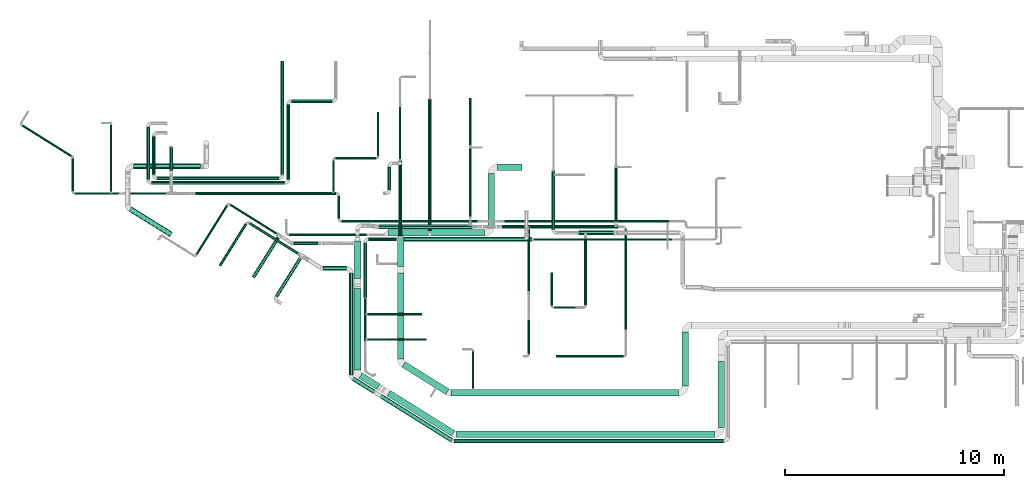
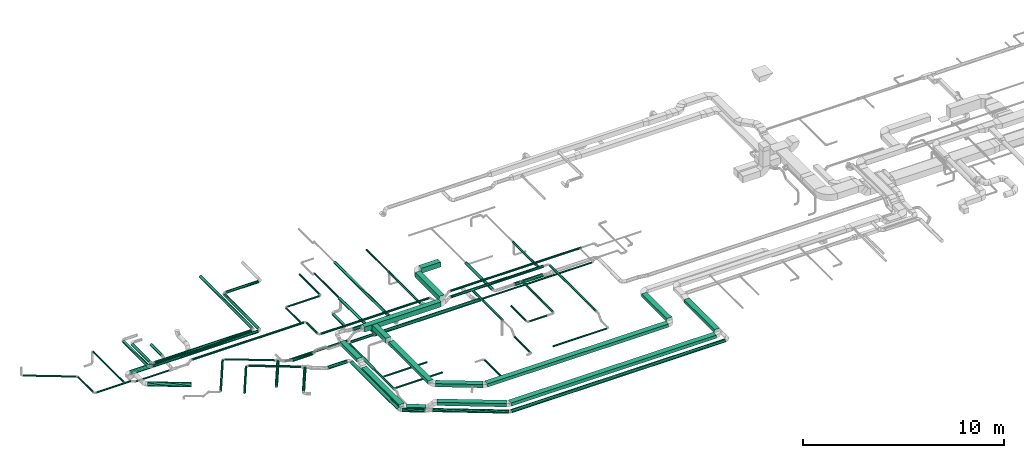
# One storey, part 1 of 60: 75 flow segments.
"""IFC2X3 building model written with IfcOpenShell, lengths in millimetres."""

from ifc_helpers import new_model, entity, si_unit, converted_unit, derived_unit, direction, frame, origin, origin_2d_with_axis, place, context, subcontext, project, spatial, rectangle, circle, extrude, type_object, element, save


model = new_model("IFC2X3")

# Units and contexts
model_context = context("Model", 3, precision=0.01, world=origin(), true_north=direction((6.12303176911189e-17, 1.0)))
body_context = subcontext(model_context, "Body", "Model", "MODEL_VIEW")
ifc_project = project(units=[si_unit("LENGTHUNIT", "METRE", prefix="MILLI"), si_unit("AREAUNIT", "SQUARE_METRE"), si_unit("VOLUMEUNIT", "CUBIC_METRE"), converted_unit("PLANEANGLEUNIT", "DEGREE", entity("IfcRatioMeasure", 0.0174532925199433), si_unit("PLANEANGLEUNIT", "RADIAN"), dimensions=[0, 0, 0, 0, 0, 0, 0]), si_unit("MASSUNIT", "GRAM", prefix="KILO"), derived_unit("MASSDENSITYUNIT", [(si_unit("MASSUNIT", "GRAM", prefix="KILO"), 1), (si_unit("LENGTHUNIT", "METRE"), -3)]), derived_unit("MOMENTOFINERTIAUNIT", [(si_unit("LENGTHUNIT", "METRE"), 4)]), si_unit("TIMEUNIT", "SECOND"), si_unit("FREQUENCYUNIT", "HERTZ"), si_unit("THERMODYNAMICTEMPERATUREUNIT", "DEGREE_CELSIUS"), derived_unit("THERMALTRANSMITTANCEUNIT", [(si_unit("MASSUNIT", "GRAM", prefix="KILO"), 1), (si_unit("THERMODYNAMICTEMPERATUREUNIT", "KELVIN"), -1), (si_unit("TIMEUNIT", "SECOND"), -3)]), derived_unit("VOLUMETRICFLOWRATEUNIT", [(si_unit("LENGTHUNIT", "METRE"), 3), (si_unit("TIMEUNIT", "SECOND"), -1)]), derived_unit("MASSFLOWRATEUNIT", [(si_unit("MASSUNIT", "GRAM", prefix="KILO"), 1), (si_unit("TIMEUNIT", "SECOND"), -1)]), derived_unit("ROTATIONALFREQUENCYUNIT", [(si_unit("TIMEUNIT", "SECOND"), -1)]), si_unit("ELECTRICCURRENTUNIT", "AMPERE"), si_unit("ELECTRICVOLTAGEUNIT", "VOLT"), si_unit("POWERUNIT", "WATT"), si_unit("FORCEUNIT", "NEWTON", prefix="KILO"), si_unit("ILLUMINANCEUNIT", "LUX"), si_unit("LUMINOUSFLUXUNIT", "LUMEN"), si_unit("LUMINOUSINTENSITYUNIT", "CANDELA"), derived_unit("USERDEFINED", [(si_unit("MASSUNIT", "GRAM", prefix="KILO"), -1), (si_unit("LENGTHUNIT", "METRE"), -2), (si_unit("TIMEUNIT", "SECOND"), 3), (si_unit("LUMINOUSFLUXUNIT", "LUMEN"), 1)]), derived_unit("LINEARVELOCITYUNIT", [(si_unit("LENGTHUNIT", "METRE"), 1), (si_unit("TIMEUNIT", "SECOND"), -1)]), si_unit("PRESSUREUNIT", "PASCAL"), derived_unit("USERDEFINED", [(si_unit("LENGTHUNIT", "METRE"), -2), (si_unit("MASSUNIT", "GRAM", prefix="KILO"), 1), (si_unit("TIMEUNIT", "SECOND"), -2)]), derived_unit("LINEARFORCEUNIT", [(si_unit("MASSUNIT", "GRAM", prefix="KILO"), 1), (si_unit("LENGTHUNIT", "METRE"), 1), (si_unit("TIMEUNIT", "SECOND"), -2), (si_unit("LENGTHUNIT", "METRE"), -1)]), derived_unit("PLANARFORCEUNIT", [(si_unit("MASSUNIT", "GRAM", prefix="KILO"), 1), (si_unit("LENGTHUNIT", "METRE"), 1), (si_unit("TIMEUNIT", "SECOND"), -2), (si_unit("LENGTHUNIT", "METRE"), -2)])], contexts=[model_context])

# Site, building, storey
site_placement = place(None, origin())
site = spatial("IfcSite", under=ifc_project, at=site_placement, CompositionType="ELEMENT")
building_placement = place(site_placement, origin())
building = spatial("IfcBuilding", under=site, at=building_placement, CompositionType="ELEMENT")
storey_placement = place(building_placement, frame((0.0, 0.0, 19800.0)))
storey = spatial("IfcBuildingStorey", under=building, at=storey_placement, CompositionType="ELEMENT", Elevation=19800.0)

# Flow segments
duct_segment_type_1 = type_object("IfcDuctSegmentType", PredefinedType="NOTDEFINED")
flow_segment_1_placement = place(storey_placement, frame((23050.9, 12650.16, 3420.0)))
element("IfcFlowSegment", 1, at=flow_segment_1_placement, inside=storey, type_object=duct_segment_type_1, context=body_context, shape_type="SweptSolid", body=[
    extrude(rectangle(XDim=1118.21565686797, YDim=299.999999999999, at=origin_2d_with_axis()), frame((559.11, 150.0, 0.0), z_axis=(0.0, 0.0, 1.0), x_axis=(-1.0, 0.0, 0.0)), (0.0, 0.0, 1.0), 300.000000000001),
])
flow_segment_2_placement = place(storey_placement, frame((18466.2, 8270.16, 3420.0)))
element("IfcFlowSegment", 2, at=flow_segment_2_placement, inside=storey, type_object=duct_segment_type_1, context=body_context, shape_type="SweptSolid", body=[
    extrude(rectangle(XDim=1355.00000000017, YDim=300.000000000001, at=origin_2d_with_axis()), frame((150.0, 677.5, 0.0), z_axis=(0.0, 0.0, 1.0), x_axis=(0.0, 1.0, 0.0)), (0.0, 0.0, 1.0), 300.000000000001),
])
flow_segment_3_placement = place(storey_placement, frame((18466.2, 4051.46, 3500.0)))
element("IfcFlowSegment", 3, at=flow_segment_3_placement, inside=storey, type_object=duct_segment_type_1, context=body_context, shape_type="SweptSolid", body=[
    extrude(rectangle(XDim=3918.70556476441, YDim=299.999999999999, at=origin_2d_with_axis()), frame((150.0, 1959.35, 0.0), z_axis=(0.0, 0.0, 1.0), x_axis=(0.0, 1.0, 0.0)), (0.0, 0.0, 1.0), 199.999999999998),
])
flow_segment_4_placement = place(storey_placement, frame((18677.74, 2422.18, 3500.0)))
element("IfcFlowSegment", 4, at=flow_segment_4_placement, inside=storey, type_object=duct_segment_type_1, context=body_context, shape_type="SweptSolid", body=[
    extrude(rectangle(XDim=2354.45698867286, YDim=300.000000000001, at=origin_2d_with_axis()), frame((1077.84, 751.04, 0.0), z_axis=(0.0, 0.0, 1.0), x_axis=(-0.848052743777572, 0.529911826412028, 0.0)), (0.0, 0.0, 1.0), 199.999999999998),
])
flow_segment_5_placement = place(storey_placement, frame((20912.9, 2353.8, 3500.0)))
element("IfcFlowSegment", 5, at=flow_segment_5_placement, inside=storey, type_object=duct_segment_type_1, context=body_context, shape_type="SweptSolid", body=[
    extrude(rectangle(XDim=10389.9997537247, YDim=300.0, at=origin_2d_with_axis()), frame((5195.0, 150.0, 0.0)), (0.0, 0.0, 1.0), 199.999999999998),
])
flow_segment_6_placement = place(storey_placement, frame((31452.9, 2803.8, 3500.0)))
element("IfcFlowSegment", 6, at=flow_segment_6_placement, inside=storey, type_object=duct_segment_type_1, context=body_context, shape_type="SweptSolid", body=[
    extrude(rectangle(XDim=2481.24999999997, YDim=300.000000000001, at=origin_2d_with_axis()), frame((150.0, 1240.62, 0.0), z_axis=(0.0, 0.0, 1.0), x_axis=(0.0, 1.0, 0.0)), (0.0, 0.0, 1.0), 199.999999999998),
])
flow_segment_7_placement = place(storey_placement, frame((33096.97, 905.34, 3400.0)))
element("IfcFlowSegment", 7, at=flow_segment_7_placement, inside=storey, type_object=duct_segment_type_1, context=body_context, shape_type="SweptSolid", body=[
    extrude(rectangle(XDim=3020.00000000003, YDim=300.000000000001, at=origin_2d_with_axis()), frame((150.0, 1510.0, 0.0), z_axis=(0.0, 0.0, 1.0), x_axis=(0.0, 1.0, 0.0)), (0.0, 0.0, 1.0), 199.999999999998),
])
flow_segment_8_placement = place(storey_placement, frame((21169.99, 455.34, 3400.0)))
element("IfcFlowSegment", 8, at=flow_segment_8_placement, inside=storey, type_object=duct_segment_type_1, context=body_context, shape_type="SweptSolid", body=[
    extrude(rectangle(XDim=11776.9796368242, YDim=300.0, at=origin_2d_with_axis()), frame((5888.49, 150.0, 0.0)), (0.0, 0.0, 1.0), 199.999999999998),
])
flow_segment_9_placement = place(storey_placement, frame((16711.76, 2651.52, 3050.0)))
element("IfcFlowSegment", 9, at=flow_segment_9_placement, inside=storey, type_object=duct_segment_type_1, context=body_context, shape_type="SweptSolid", body=[
    extrude(rectangle(XDim=960.446609406749, YDim=299.999999999999, at=origin_2d_with_axis()), frame((486.74, 381.68, 0.0), z_axis=(0.0, 0.0, 1.0), x_axis=(-0.848052743777576, 0.529911826412022, 0.0)), (0.0, 0.0, 1.0), 199.999999999998),
])
flow_segment_10_placement = place(storey_placement, frame((16500.22, 3542.1, 3050.0)))
element("IfcFlowSegment", 10, at=flow_segment_10_placement, inside=storey, type_object=duct_segment_type_1, context=body_context, shape_type="SweptSolid", body=[
    extrude(rectangle(XDim=3711.41542365597, YDim=299.999999999999, at=origin_2d_with_axis()), frame((150.0, 1855.71, 0.0), z_axis=(0.0, 0.0, 1.0), x_axis=(0.0, 1.0, 0.0)), (0.0, 0.0, 1.0), 199.999999999998),
])
flow_segment_11_placement = place(storey_placement, frame((17998.73, 523.72, 3400.0)))
element("IfcFlowSegment", 11, at=flow_segment_11_placement, inside=storey, type_object=duct_segment_type_1, context=body_context, shape_type="SweptSolid", body=[
    extrude(rectangle(XDim=3458.28055579859, YDim=300.000000000001, at=origin_2d_with_axis()), frame((1545.89, 1043.5, 0.0), z_axis=(0.0, 0.0, 1.0), x_axis=(-0.84805274377757, 0.529911826412032, 0.0)), (0.0, 0.0, 1.0), 199.999999999998),
])
flow_segment_12_placement = place(storey_placement, frame((16500.22, 7721.44, 3310.82)))
element("IfcFlowSegment", 12, at=flow_segment_12_placement, inside=storey, type_object=duct_segment_type_1, context=body_context, shape_type="SweptSolid", body=[
    extrude(rectangle(XDim=1699.44660940673, YDim=300.000000000001, at=origin_2d_with_axis()), frame((150.0, 849.72, 0.0), z_axis=(0.0, 0.0, 1.0), x_axis=(0.0, -1.0, 0.0)), (0.0, 0.0, 1.0), 199.999999999998),
])
flow_segment_13_placement = place(storey_placement, frame((18057.77, 9645.16, 3420.0)))
element("IfcFlowSegment", 13, at=flow_segment_13_placement, inside=storey, type_object=duct_segment_type_1, context=body_context, shape_type="SweptSolid", body=[
    extrude(rectangle(XDim=4393.12500000002, YDim=300.0, at=origin_2d_with_axis()), frame((2196.56, 150.0, 0.0)), (0.0, 0.0, 1.0), 300.000000000001),
])
flow_segment_14_placement = place(storey_placement, frame((22600.9, 10095.16, 3420.0)))
element("IfcFlowSegment", 14, at=flow_segment_14_placement, inside=storey, type_object=duct_segment_type_1, context=body_context, shape_type="SweptSolid", body=[
    extrude(rectangle(XDim=2405.00000000005, YDim=300.000000000001, at=origin_2d_with_axis()), frame((150.0, 1202.5, 0.0), z_axis=(0.0, 0.0, 1.0), x_axis=(0.0, 1.0, 0.0)), (0.0, 0.0, 1.0), 300.000000000001),
])
duct_segment_type_2 = type_object("IfcDuctSegmentType", PredefinedType="NOTDEFINED")
flow_segment_15_placement = place(storey_placement, frame((7018.44, 12237.58, 3568.4)))
element("IfcFlowSegment", 15, at=flow_segment_15_placement, inside=storey, type_object=duct_segment_type_2, context=body_context, shape_type="SweptSolid", body=[
    extrude(circle(Radius=80.0, at=origin_2d_with_axis()), frame((81.6, 0.0, 81.6), z_axis=(0.0, 1.0, 0.0), x_axis=(-1.0, 0.0, 0.0)), (0.0, 0.0, 1.0), 2402.81249999998),
])
flow_segment_16_placement = place(storey_placement, frame((7260.03, 11995.99, 3568.4)))
element("IfcFlowSegment", 16, at=flow_segment_16_placement, inside=storey, type_object=duct_segment_type_2, context=body_context, shape_type="SweptSolid", body=[
    extrude(circle(Radius=80.0, at=origin_2d_with_axis()), frame((0.0, 81.6, 81.6), z_axis=(1.0, 0.0, 0.0), x_axis=(0.0, -1.0, 0.0)), (0.0, 0.0, 1.0), 6061.87500000002),
])
flow_segment_17_placement = place(storey_placement, frame((13400.31, 12237.58, 3568.4)))
element("IfcFlowSegment", 17, at=flow_segment_17_placement, inside=storey, type_object=duct_segment_type_2, context=body_context, shape_type="SweptSolid", body=[
    extrude(circle(Radius=80.0, at=origin_2d_with_axis()), frame((81.6, 0.0, 81.6), z_axis=(0.0, 1.0, 0.0), x_axis=(1.0, 0.0, 0.0)), (0.0, 0.0, 1.0), 3409.06249999998),
])
flow_segment_18_placement = place(storey_placement, frame((13641.91, 15725.05, 3568.4)))
element("IfcFlowSegment", 18, at=flow_segment_18_placement, inside=storey, type_object=duct_segment_type_2, context=body_context, shape_type="SweptSolid", body=[
    extrude(circle(Radius=80.0, at=origin_2d_with_axis()), frame((0.0, 81.6, 81.6), z_axis=(1.0, 0.0, 0.0), x_axis=(0.0, -1.0, 0.0)), (0.0, 0.0, 1.0), 1848.12500000002),
])
flow_segment_19_placement = place(storey_placement, frame((7269.59, 12456.79, 3568.4)))
element("IfcFlowSegment", 19, at=flow_segment_19_placement, inside=storey, type_object=duct_segment_type_2, context=body_context, shape_type="SweptSolid", body=[
    extrude(circle(Radius=80.0, at=origin_2d_with_axis()), frame((81.6, 0.0, 81.6), z_axis=(0.0, 1.0, 0.0), x_axis=(-1.0, 0.0, 0.0)), (0.0, 0.0, 1.0), 1742.50000000001),
])
flow_segment_20_placement = place(storey_placement, frame((7511.19, 12215.2, 3568.4)))
element("IfcFlowSegment", 20, at=flow_segment_20_placement, inside=storey, type_object=duct_segment_type_2, context=body_context, shape_type="SweptSolid", body=[
    extrude(circle(Radius=80.0, at=origin_2d_with_axis()), frame((0.0, 81.6, 81.6), z_axis=(1.0, 0.0, 0.0), x_axis=(0.0, -1.0, 0.0)), (0.0, 0.0, 1.0), 5551.25000000001),
])
flow_segment_21_placement = place(storey_placement, frame((13140.84, 12456.79, 3568.4)))
element("IfcFlowSegment", 21, at=flow_segment_21_placement, inside=storey, type_object=duct_segment_type_2, context=body_context, shape_type="SweptSolid", body=[
    extrude(circle(Radius=80.0, at=origin_2d_with_axis()), frame((81.6, 0.0, 81.6), z_axis=(0.0, 1.0, 0.0), x_axis=(1.0, 0.0, 0.0)), (0.0, 0.0, 1.0), 5183.60388486845),
])
flow_segment_22_placement = place(storey_placement, frame((8068.1, 12656.11, 3568.4)))
element("IfcFlowSegment", 22, at=flow_segment_22_placement, inside=storey, type_object=duct_segment_type_2, context=body_context, shape_type="SweptSolid", body=[
    extrude(circle(Radius=80.0, at=origin_2d_with_axis()), frame((81.6, 0.0, 81.6), z_axis=(0.0, 1.0, 0.0), x_axis=(-1.0, 0.0, 0.0)), (0.0, 0.0, 1.0), 1059.57462925657),
])
flow_segment_23_placement = place(storey_placement, frame((3753.44, 11548.37, 3518.4)))
element("IfcFlowSegment", 23, at=flow_segment_23_placement, inside=storey, type_object=duct_segment_type_2, context=body_context, shape_type="SweptSolid", body=[
    extrude(circle(Radius=50.0, at=origin_2d_with_axis()), frame((0.0, 51.6, 51.6), z_axis=(1.0, 0.0, 0.0), x_axis=(0.0, 1.0, 0.0)), (0.0, 0.0, 1.0), 1990.91010544086),
])
flow_segment_24_placement = place(storey_placement, frame((3601.85, 11699.96, 3518.4)))
element("IfcFlowSegment", 24, at=flow_segment_24_placement, inside=storey, type_object=duct_segment_type_2, context=body_context, shape_type="SweptSolid", body=[
    extrude(circle(Radius=50.0, at=origin_2d_with_axis()), frame((51.6, 0.0, 51.6), z_axis=(0.0, 1.0, 0.0), x_axis=(1.0, 0.0, 0.0)), (0.0, 0.0, 1.0), 1508.28264031484),
])
flow_segment_25_placement = place(storey_placement, frame((1318.77, 13249.05, 3518.4)))
element("IfcFlowSegment", 25, at=flow_segment_25_placement, inside=storey, type_object=duct_segment_type_2, context=body_context, shape_type="SweptSolid", body=[
    extrude(circle(Radius=50.0, at=origin_2d_with_axis()), frame((28.09, 1455.94, 51.6), z_axis=(0.848048096156427, -0.529919264233203, 0.0), x_axis=(0.529919264233203, 0.848048096156427, 0.0)), (0.0, 0.0, 1.0), 2664.44459104297),
])
flow_segment_26_placement = place(storey_placement, frame((5348.84, 11669.96, 3518.4)))
element("IfcFlowSegment", 26, at=flow_segment_26_placement, inside=storey, type_object=duct_segment_type_2, context=body_context, shape_type="SweptSolid", body=[
    extrude(circle(Radius=50.0, at=origin_2d_with_axis()), frame((51.6, 0.0, 51.6), z_axis=(0.0, 1.0, 0.0), x_axis=(-1.0, 0.0, 0.0)), (0.0, 0.0, 1.0), 3050.0),
])
flow_segment_27_placement = place(storey_placement, frame((15735.91, 10449.96, 3585.9)))
element("IfcFlowSegment", 27, at=flow_segment_27_placement, inside=storey, type_object=duct_segment_type_2, context=body_context, shape_type="SweptSolid", body=[
    extrude(circle(Radius=62.5, at=origin_2d_with_axis()), frame((64.1, 0.0, 64.1), z_axis=(0.0, 1.0, 0.0), x_axis=(-1.0, 0.0, 0.0)), (0.0, 0.0, 1.0), 1025.00000000001),
])
flow_segment_28_placement = place(storey_placement, frame((23348.89, 10260.87, 3585.9)))
element("IfcFlowSegment", 28, at=flow_segment_28_placement, inside=storey, type_object=duct_segment_type_2, context=body_context, shape_type="SweptSolid", body=[
    extrude(circle(Radius=62.5, at=origin_2d_with_axis()), frame((0.0, 64.1, 64.1), z_axis=(1.0, 0.0, 0.0), x_axis=(0.0, -1.0, 0.0)), (0.0, 0.0, 1.0), 7520.80402351683),
])
flow_segment_29_placement = place(storey_placement, frame((9258.97, 11535.87, 3585.9)))
element("IfcFlowSegment", 29, at=flow_segment_29_placement, inside=storey, type_object=duct_segment_type_2, context=body_context, shape_type="SweptSolid", body=[
    extrude(circle(Radius=62.5, at=origin_2d_with_axis()), frame((0.0, 64.1, 64.1), z_axis=(1.0, 0.0, 0.0), x_axis=(0.0, 1.0, 0.0)), (0.0, 0.0, 1.0), 6416.03580470329),
])
flow_segment_30_placement = place(storey_placement, frame((15498.61, 11682.46, 3598.4)))
element("IfcFlowSegment", 30, at=flow_segment_30_placement, inside=storey, type_object=duct_segment_type_2, context=body_context, shape_type="SweptSolid", body=[
    extrude(circle(Radius=50.0, at=origin_2d_with_axis()), frame((51.6, 0.0, 51.6), z_axis=(0.0, 1.0, 0.0), x_axis=(1.0, 0.0, 0.0)), (0.0, 0.0, 1.0), 1418.12499999992),
])
flow_segment_31_placement = place(storey_placement, frame((15650.2, 13148.99, 3598.4)))
element("IfcFlowSegment", 31, at=flow_segment_31_placement, inside=storey, type_object=duct_segment_type_2, context=body_context, shape_type="SweptSolid", body=[
    extrude(circle(Radius=50.0, at=origin_2d_with_axis()), frame((0.0, 51.6, 51.6), z_axis=(1.0, 0.0, 0.0), x_axis=(0.0, -1.0, 0.0)), (0.0, 0.0, 1.0), 1843.12500000002),
])
flow_segment_32_placement = place(storey_placement, frame((17541.73, 13300.59, 3598.4)))
element("IfcFlowSegment", 32, at=flow_segment_32_placement, inside=storey, type_object=duct_segment_type_2, context=body_context, shape_type="SweptSolid", body=[
    extrude(circle(Radius=50.0, at=origin_2d_with_axis()), frame((51.6, 0.0, 51.6), z_axis=(0.0, 1.0, 0.0), x_axis=(1.0, 0.0, 0.0)), (0.0, 0.0, 1.0), 2021.87500000001),
])
flow_segment_33_placement = place(storey_placement, frame((6219.44, 9610.2, 3523.4)))
element("IfcFlowSegment", 33, at=flow_segment_33_placement, inside=storey, type_object=duct_segment_type_2, context=body_context, shape_type="SweptSolid", body=[
    extrude(circle(Radius=125.0, at=origin_2d_with_axis()), frame((67.84, 1274.18, 126.6), z_axis=(0.848048096156427, -0.529919264233203, 0.0), x_axis=(-0.529919264233203, -0.848048096156427, 0.0)), (0.0, 0.0, 1.0), 2201.42273713681),
])
flow_segment_34_placement = place(storey_placement, frame((13525.27, 9643.57, 3135.9)))
element("IfcFlowSegment", 34, at=flow_segment_34_placement, inside=storey, type_object=duct_segment_type_2, context=body_context, shape_type="SweptSolid", body=[
    extrude(circle(Radius=62.5, at=origin_2d_with_axis()), frame((0.0, 64.1, 64.1), z_axis=(1.0, 0.0, 0.0), x_axis=(0.0, -1.0, 0.0)), (0.0, 0.0, 1.0), 3540.72612125958),
])
flow_segment_35_placement = place(storey_placement, frame((21873.49, 2673.8, 3498.4)))
element("IfcFlowSegment", 35, at=flow_segment_35_placement, inside=storey, type_object=duct_segment_type_2, context=body_context, shape_type="SweptSolid", body=[
    extrude(circle(Radius=50.0, at=origin_2d_with_axis()), frame((51.6, 0.0, 51.6), z_axis=(0.0, 1.0, 0.0), x_axis=(1.0, 0.0, 0.0)), (0.0, 0.0, 1.0), 1716.24999999998),
])
flow_segment_36_placement = place(storey_placement, frame((18483.27, 9398.58, 3098.4)))
element("IfcFlowSegment", 36, at=flow_segment_36_placement, inside=storey, type_object=duct_segment_type_2, context=body_context, shape_type="SweptSolid", body=[
    extrude(circle(Radius=100.0, at=origin_2d_with_axis()), frame((0.0, 101.6, 101.6), z_axis=(1.0, 0.0, 0.0), x_axis=(0.0, -1.0, 0.0)), (0.0, 0.0, 1.0), 6110.00000000001),
])
flow_segment_37_placement = place(storey_placement, frame((24693.27, 9448.58, 3148.4)))
element("IfcFlowSegment", 37, at=flow_segment_37_placement, inside=storey, type_object=duct_segment_type_2, context=body_context, shape_type="SweptSolid", body=[
    extrude(circle(Radius=50.0, at=origin_2d_with_axis()), frame((0.0, 51.6, 51.6), z_axis=(1.0, 0.0, 0.0), x_axis=(0.0, 1.0, 0.0)), (0.0, 0.0, 1.0), 6307.95364376268),
])
flow_segment_38_placement = place(storey_placement, frame((17162.65, 9418.58, 3138.4)))
element("IfcFlowSegment", 38, at=flow_segment_38_placement, inside=storey, type_object=duct_segment_type_2, context=body_context, shape_type="SweptSolid", body=[
    extrude(circle(Radius=80.0, at=origin_2d_with_axis()), frame((0.0, 81.6, 81.6), z_axis=(1.0, 0.0, 0.0), x_axis=(0.0, -1.0, 0.0)), (0.0, 0.0, 1.0), 1280.62500000001),
])
flow_segment_39_placement = place(storey_placement, frame((16921.05, 6840.18, 3138.4)))
element("IfcFlowSegment", 39, at=flow_segment_39_placement, inside=storey, type_object=duct_segment_type_2, context=body_context, shape_type="SweptSolid", body=[
    extrude(circle(Radius=80.0, at=origin_2d_with_axis()), frame((81.6, 0.0, 81.6), z_axis=(0.0, 1.0, 0.0), x_axis=(-1.0, 0.0, 0.0)), (0.0, 0.0, 1.0), 2500.00000000001),
])
flow_segment_40_placement = place(storey_placement, frame((16938.55, 4850.18, 3155.9)))
element("IfcFlowSegment", 40, at=flow_segment_40_placement, inside=storey, type_object=duct_segment_type_2, context=body_context, shape_type="SweptSolid", body=[
    extrude(circle(Radius=62.5, at=origin_2d_with_axis()), frame((64.1, 0.0, 64.1), z_axis=(0.0, 1.0, 0.0), x_axis=(-1.0, 0.0, 0.0)), (0.0, 0.0, 1.0), 1955.0),
])
flow_segment_41_placement = place(storey_placement, frame((17085.15, 4884.48, 3168.4)))
element("IfcFlowSegment", 41, at=flow_segment_41_placement, inside=storey, type_object=duct_segment_type_2, context=body_context, shape_type="SweptSolid", body=[
    extrude(circle(Radius=50.0, at=origin_2d_with_axis()), frame((0.0, 51.6, 51.6), z_axis=(1.0, 0.0, 0.0), x_axis=(0.0, -1.0, 0.0)), (0.0, 0.0, 1.0), 2719.99999999998),
])
flow_segment_42_placement = place(storey_placement, frame((17085.15, 6034.6, 3168.4)))
element("IfcFlowSegment", 42, at=flow_segment_42_placement, inside=storey, type_object=duct_segment_type_2, context=body_context, shape_type="SweptSolid", body=[
    extrude(circle(Radius=50.0, at=origin_2d_with_axis()), frame((0.0, 51.6, 51.6), z_axis=(1.0, 0.0, 0.0), x_axis=(0.0, -1.0, 0.0)), (0.0, 0.0, 1.0), 2499.99999999998),
])
flow_segment_43_placement = place(storey_placement, frame((18513.74, 9620.18, 3118.4)))
element("IfcFlowSegment", 43, at=flow_segment_43_placement, inside=storey, type_object=duct_segment_type_2, context=body_context, shape_type="SweptSolid", body=[
    extrude(circle(Radius=80.0, at=origin_2d_with_axis()), frame((81.6, 0.0, 81.6), z_axis=(0.0, 1.0, 0.0), x_axis=(1.0, 0.0, 0.0)), (0.0, 0.0, 1.0), 3479.99999999999),
])
flow_segment_44_placement = place(storey_placement, frame((18543.74, 13160.18, 3148.4)))
element("IfcFlowSegment", 44, at=flow_segment_44_placement, inside=storey, type_object=duct_segment_type_2, context=body_context, shape_type="SweptSolid", body=[
    extrude(circle(Radius=50.0, at=origin_2d_with_axis()), frame((51.6, 0.0, 51.6), z_axis=(0.0, 1.0, 0.0), x_axis=(1.0, 0.0, 0.0)), (0.0, 0.0, 1.0), 2383.57864376271),
])
flow_segment_45_placement = place(storey_placement, frame((18013.74, 11758.09, 2478.4)))
element("IfcFlowSegment", 45, at=flow_segment_45_placement, inside=storey, type_object=duct_segment_type_2, context=body_context, shape_type="SweptSolid", body=[
    extrude(circle(Radius=80.0, at=origin_2d_with_axis()), frame((81.6, 0.0, 81.6), z_axis=(0.0, 1.0, 0.0), x_axis=(-1.0, 0.0, 0.0)), (0.0, 0.0, 1.0), 1055.00000000001),
])
flow_segment_46_placement = place(storey_placement, frame((17620.71, 9976.81, 3383.4)))
element("IfcFlowSegment", 46, at=flow_segment_46_placement, inside=storey, type_object=duct_segment_type_2, context=body_context, shape_type="SweptSolid", body=[
    extrude(circle(Radius=100.0, at=origin_2d_with_axis()), frame((0.0, 101.6, 101.6), z_axis=(1.0, 0.0, 0.0), x_axis=(0.0, 1.0, 0.0)), (0.0, 0.0, 1.0), 4269.51334287228),
])
flow_segment_47_placement = place(storey_placement, frame((28826.13, 5380.9, 3420.9)))
element("IfcFlowSegment", 47, at=flow_segment_47_placement, inside=storey, type_object=duct_segment_type_2, context=body_context, shape_type="SweptSolid", body=[
    extrude(circle(Radius=62.5, at=origin_2d_with_axis()), frame((64.1, 0.0, 64.1), z_axis=(0.0, 1.0, 0.0), x_axis=(-1.0, 0.0, 0.0)), (0.0, 0.0, 1.0), 4572.50000000002),
])
flow_segment_48_placement = place(storey_placement, frame((25710.22, 4118.35, 3148.4)))
element("IfcFlowSegment", 48, at=flow_segment_48_placement, inside=storey, type_object=duct_segment_type_2, context=body_context, shape_type="SweptSolid", body=[
    extrude(circle(Radius=50.0, at=origin_2d_with_axis()), frame((0.0, 51.6, 51.6), z_axis=(1.0, 0.0, 0.0), x_axis=(0.0, 1.0, 0.0)), (0.0, 0.0, 1.0), 3080.00000000002),
])
flow_segment_49_placement = place(storey_placement, frame((28381.16, 10314.85, 3236.23)))
element("IfcFlowSegment", 49, at=flow_segment_49_placement, inside=storey, type_object=duct_segment_type_2, context=body_context, shape_type="SweptSolid", body=[
    extrude(circle(Radius=62.5, at=origin_2d_with_axis()), frame((64.1, 0.0, 64.1), z_axis=(0.0, 1.0, 0.0), x_axis=(1.0, 0.0, 0.0)), (0.0, 0.0, 1.0), 2568.87739091965),
])
flow_segment_50_placement = place(storey_placement, frame((21732.73, 10538.38, 3235.9)))
element("IfcFlowSegment", 50, at=flow_segment_50_placement, inside=storey, type_object=duct_segment_type_2, context=body_context, shape_type="SweptSolid", body=[
    extrude(circle(Radius=62.5, at=origin_2d_with_axis()), frame((64.1, 0.0, 64.1), z_axis=(0.0, 1.0, 0.0), x_axis=(1.0, 0.0, 0.0)), (0.0, 0.0, 1.0), 3226.31324830042),
])
flow_segment_51_placement = place(storey_placement, frame((21745.23, 13789.7, 3248.4)))
element("IfcFlowSegment", 51, at=flow_segment_51_placement, inside=storey, type_object=duct_segment_type_2, context=body_context, shape_type="SweptSolid", body=[
    extrude(circle(Radius=50.0, at=origin_2d_with_axis()), frame((51.6, 0.0, 51.6), z_axis=(0.0, 1.0, 0.0), x_axis=(1.0, 0.0, 0.0)), (0.0, 0.0, 1.0), 2154.99999999999),
])
flow_segment_52_placement = place(storey_placement, frame((24406.12, 7018.39, 3420.9)))
element("IfcFlowSegment", 52, at=flow_segment_52_placement, inside=storey, type_object=duct_segment_type_2, context=body_context, shape_type="SweptSolid", body=[
    extrude(circle(Radius=62.5, at=origin_2d_with_axis()), frame((64.1, 0.0, 64.1), z_axis=(0.0, 1.0, 0.0), x_axis=(-1.0, 0.0, 0.0)), (0.0, 0.0, 1.0), 2960.01517691835),
])
flow_segment_53_placement = place(storey_placement, frame((24418.62, 4269.95, 3148.4)))
element("IfcFlowSegment", 53, at=flow_segment_53_placement, inside=storey, type_object=duct_segment_type_2, context=body_context, shape_type="SweptSolid", body=[
    extrude(circle(Radius=50.0, at=origin_2d_with_axis()), frame((51.6, 0.0, 51.6), z_axis=(0.0, 1.0, 0.0), x_axis=(-1.0, 0.0, 0.0)), (0.0, 0.0, 1.0), 1551.01613608468),
])
flow_segment_54_placement = place(storey_placement, frame((13713.81, 9238.83, 3343.4)))
element("IfcFlowSegment", 54, at=flow_segment_54_placement, inside=storey, type_object=duct_segment_type_2, context=body_context, shape_type="SweptSolid", body=[
    extrude(circle(Radius=80.0, at=origin_2d_with_axis()), frame((0.0, 81.6, 81.6), z_axis=(1.0, 0.0, 0.0), x_axis=(0.0, -1.0, 0.0)), (0.0, 0.0, 1.0), 1127.84656829896),
])
flow_segment_55_placement = place(storey_placement, frame((10814.85, 9715.33, 3373.4)))
element("IfcFlowSegment", 55, at=flow_segment_55_placement, inside=storey, type_object=duct_segment_type_2, context=body_context, shape_type="SweptSolid", body=[
    extrude(circle(Radius=50.0, at=origin_2d_with_axis()), frame((28.09, 1370.35, 51.6), z_axis=(0.848048096156418, -0.529919264233218, 0.0), x_axis=(0.529919264233218, 0.848048096156418, 0.0)), (0.0, 0.0, 1.0), 2502.929110992),
])
flow_segment_56_placement = place(storey_placement, frame((9257.69, 8779.77, 3373.4)))
element("IfcFlowSegment", 56, at=flow_segment_56_placement, inside=storey, type_object=duct_segment_type_2, context=body_context, shape_type="SweptSolid", body=[
    extrude(circle(Radius=50.0, at=origin_2d_with_axis()), frame((44.0, 28.09, 51.6), z_axis=(0.529919264233221, 0.848048096156416, 0.0), x_axis=(-0.848048096156416, 0.529919264233221, 0.0)), (0.0, 0.0, 1.0), 2648.43040891653),
])
flow_segment_57_placement = place(storey_placement, frame((11827.46, 7718.15, 3343.4)))
element("IfcFlowSegment", 57, at=flow_segment_57_placement, inside=storey, type_object=duct_segment_type_2, context=body_context, shape_type="SweptSolid", body=[
    extrude(circle(Radius=80.0, at=origin_2d_with_axis()), frame((69.44, 43.99, 81.6), z_axis=(0.529911353855658, 0.848053039057619, 0.0), x_axis=(-0.848053039057619, 0.529911353855658, 0.0)), (0.0, 0.0, 1.0), 2159.99925378245),
])
flow_segment_58_placement = place(storey_placement, frame((21062.72, 198.55, 3128.29)))
element("IfcFlowSegment", 58, at=flow_segment_58_placement, inside=storey, type_object=duct_segment_type_2, context=body_context, shape_type="SweptSolid", body=[
    extrude(circle(Radius=100.0, at=origin_2d_with_axis()), frame((0.0, 101.6, 101.6), z_axis=(1.0, 0.0, 0.0), x_axis=(0.0, 1.0, 0.0)), (0.0, 0.0, 1.0), 12282.6575870386),
])
flow_segment_59_placement = place(storey_placement, frame((16258.95, 3313.36, 3088.4)))
element("IfcFlowSegment", 59, at=flow_segment_59_placement, inside=storey, type_object=duct_segment_type_2, context=body_context, shape_type="SweptSolid", body=[
    extrude(circle(Radius=100.0, at=origin_2d_with_axis()), frame((101.6, 0.0, 101.6), z_axis=(0.0, 1.0, 0.0), x_axis=(1.0, 0.0, 0.0)), (0.0, 0.0, 1.0), 4662.57228294485),
])
flow_segment_60_placement = place(storey_placement, frame((17682.86, 244.14, 3128.29)))
element("IfcFlowSegment", 60, at=flow_segment_60_placement, inside=storey, type_object=duct_segment_type_2, context=body_context, shape_type="SweptSolid", body=[
    extrude(circle(Radius=100.0, at=origin_2d_with_axis()), frame((54.59, 2097.99, 101.6), z_axis=(0.848052743777566, -0.529911826412037, 0.0), x_axis=(0.529911826412037, 0.848052743777566, 0.0)), (0.0, 0.0, 1.0), 3796.0877406554),
])
flow_segment_61_placement = place(storey_placement, frame((16399.98, 2464.12, 3088.4)))
element("IfcFlowSegment", 61, at=flow_segment_61_placement, inside=storey, type_object=duct_segment_type_2, context=body_context, shape_type="SweptSolid", body=[
    extrude(circle(Radius=100.0, at=origin_2d_with_axis()), frame((1003.98, 86.4, 101.6), z_axis=(-0.848052743777568, 0.529911826412035, 0.0), x_axis=(-0.529911826412035, -0.848052743777568, 0.0)), (0.0, 0.0, 1.0), 1119.5013996151),
])
flow_segment_62_placement = place(storey_placement, frame((15085.88, 8074.34, 3088.4)))
element("IfcFlowSegment", 62, at=flow_segment_62_placement, inside=storey, type_object=duct_segment_type_2, context=body_context, shape_type="SweptSolid", body=[
    extrude(circle(Radius=100.0, at=origin_2d_with_axis()), frame((0.0, 101.6, 101.6), z_axis=(1.0, 0.0, 0.0), x_axis=(0.0, 1.0, 0.0)), (0.0, 0.0, 1.0), 1074.6693973151),
])
flow_segment_63_placement = place(storey_placement, frame((11696.59, 8796.01, 3176.49)))
element("IfcFlowSegment", 63, at=flow_segment_63_placement, inside=storey, type_object=duct_segment_type_2, context=body_context, shape_type="SweptSolid", body=[
    extrude(circle(Radius=62.5, at=origin_2d_with_axis()), frame((2252.24, 54.6, 64.1), z_axis=(-0.848052743777578, 0.529911826412019, 0.0), x_axis=(0.529911826412019, 0.848052743777578, 0.0)), (0.0, 0.0, 1.0), 2614.8419379902),
])
flow_segment_64_placement = place(storey_placement, frame((10315.18, 8258.51, 3176.49)))
element("IfcFlowSegment", 64, at=flow_segment_64_placement, inside=storey, type_object=duct_segment_type_2, context=body_context, shape_type="SweptSolid", body=[
    extrude(circle(Radius=62.5, at=origin_2d_with_axis()), frame((54.6, 34.72, 64.1), z_axis=(0.529919264233214, 0.848048096156421, 0.0), x_axis=(-0.848048096156421, 0.529919264233214, 0.0)), (0.0, 0.0, 1.0), 2244.27424480063),
])
flow_segment_65_placement = place(storey_placement, frame((12883.08, 6851.41, 3168.4)))
element("IfcFlowSegment", 65, at=flow_segment_65_placement, inside=storey, type_object=duct_segment_type_2, context=body_context, shape_type="SweptSolid", body=[
    extrude(circle(Radius=80.0, at=origin_2d_with_axis()), frame((69.44, 43.99, 81.6), z_axis=(0.529911826411941, 0.848052743777627, 0.0), x_axis=(-0.848052743777627, 0.529911826411941, 0.0)), (0.0, 0.0, 1.0), 2066.48104797314),
])
flow_segment_66_placement = place(storey_placement, frame((26750.56, 9698.72, 3083.4)))
element("IfcFlowSegment", 66, at=flow_segment_66_placement, inside=storey, type_object=duct_segment_type_2, context=body_context, shape_type="SweptSolid", body=[
    extrude(circle(Radius=100.0, at=origin_2d_with_axis()), frame((0.0, 101.6, 101.6), z_axis=(1.0, 0.0, 0.0), x_axis=(0.0, 1.0, 0.0)), (0.0, 0.0, 1.0), 1601.04608378761),
])
flow_segment_67_placement = place(storey_placement, frame((25508.65, 9960.32, 3103.4)))
element("IfcFlowSegment", 67, at=flow_segment_67_placement, inside=storey, type_object=duct_segment_type_2, context=body_context, shape_type="SweptSolid", body=[
    extrude(circle(Radius=80.0, at=origin_2d_with_axis()), frame((81.6, 0.0, 81.6), z_axis=(0.0, 1.0, 0.0), x_axis=(1.0, 0.0, 0.0)), (0.0, 0.0, 1.0), 2649.68749999999),
])
flow_segment_68_placement = place(storey_placement, frame((25615.9, 6336.22, 3348.4)))
element("IfcFlowSegment", 68, at=flow_segment_68_placement, inside=storey, type_object=duct_segment_type_2, context=body_context, shape_type="SweptSolid", body=[
    extrude(circle(Radius=50.0, at=origin_2d_with_axis()), frame((0.0, 51.6, 51.6), z_axis=(1.0, 0.0, 0.0), x_axis=(0.0, 1.0, 0.0)), (0.0, 0.0, 1.0), 1001.25),
])
flow_segment_69_placement = place(storey_placement, frame((25464.3, 6487.82, 3348.4)))
element("IfcFlowSegment", 69, at=flow_segment_69_placement, inside=storey, type_object=duct_segment_type_2, context=body_context, shape_type="SweptSolid", body=[
    extrude(circle(Radius=50.0, at=origin_2d_with_axis()), frame((51.6, 0.0, 51.6), z_axis=(0.0, 1.0, 0.0), x_axis=(1.0, 0.0, 0.0)), (0.0, 0.0, 1.0), 1512.50000000001),
])
flow_segment_70_placement = place(storey_placement, frame((26996.8, 6512.82, 3335.9)))
element("IfcFlowSegment", 70, at=flow_segment_70_placement, inside=storey, type_object=duct_segment_type_2, context=body_context, shape_type="SweptSolid", body=[
    extrude(circle(Radius=62.5, at=origin_2d_with_axis()), frame((64.1, 0.0, 64.1), z_axis=(0.0, 1.0, 0.0), x_axis=(1.0, 0.0, 0.0)), (0.0, 0.0, 1.0), 3035.72330470338),
])
flow_segment_71_placement = place(storey_placement, frame((6419.75, 12706.75, 2973.49)))
element("IfcFlowSegment", 71, at=flow_segment_71_placement, inside=storey, type_object=duct_segment_type_2, context=body_context, shape_type="SweptSolid", body=[
    extrude(circle(Radius=125.0, at=origin_2d_with_axis()), frame((0.0, 126.6, 126.6), z_axis=(1.0, 0.0, 0.0), x_axis=(0.0, -1.0, 0.0)), (0.0, 0.0, 1.0), 3075.00000000003),
])
flow_segment_72_placement = place(storey_placement, frame((15925.01, 10260.87, 3585.9)))
element("IfcFlowSegment", 72, at=flow_segment_72_placement, inside=storey, type_object=duct_segment_type_2, context=body_context, shape_type="SweptSolid", body=[
    extrude(circle(Radius=62.5, at=origin_2d_with_axis()), frame((0.0, 64.1, 64.1), z_axis=(1.0, 0.0, 0.0), x_axis=(0.0, -1.0, 0.0)), (0.0, 0.0, 1.0), 6213.22330470339),
])
flow_segment_73_placement = place(storey_placement, frame((23239.04, 9996.81, 3403.4)))
element("IfcFlowSegment", 73, at=flow_segment_73_placement, inside=storey, type_object=duct_segment_type_2, context=body_context, shape_type="SweptSolid", body=[
    extrude(circle(Radius=80.0, at=origin_2d_with_axis()), frame((0.0, 81.6, 81.6), z_axis=(1.0, 0.0, 0.0), x_axis=(0.0, 1.0, 0.0)), (0.0, 0.0, 1.0), 5311.17749006093),
])
flow_segment_74_placement = place(storey_placement, frame((6036.53, 11548.37, 3398.4)))
element("IfcFlowSegment", 74, at=flow_segment_74_placement, inside=storey, type_object=duct_segment_type_2, context=body_context, shape_type="SweptSolid", body=[
    extrude(circle(Radius=50.0, at=origin_2d_with_axis()), frame((0.0, 51.6, 51.6), z_axis=(1.0, 0.0, 0.0), x_axis=(0.0, 1.0, 0.0)), (0.0, 0.0, 1.0), 1893.16010544088),
])
flow_segment_75_placement = place(storey_placement, frame((19873.44, 9885.16, 3118.33)))
element("IfcFlowSegment", 75, at=flow_segment_75_placement, inside=storey, type_object=duct_segment_type_2, context=body_context, shape_type="SweptSolid", body=[
    extrude(circle(Radius=80.0, at=origin_2d_with_axis()), frame((81.6, 0.0, 81.6), z_axis=(0.0, 1.0, 0.0), x_axis=(-1.0, 0.0, 0.0)), (0.0, 0.0, 1.0), 6018.74999999989),
])

save(model, "model.ifc")
